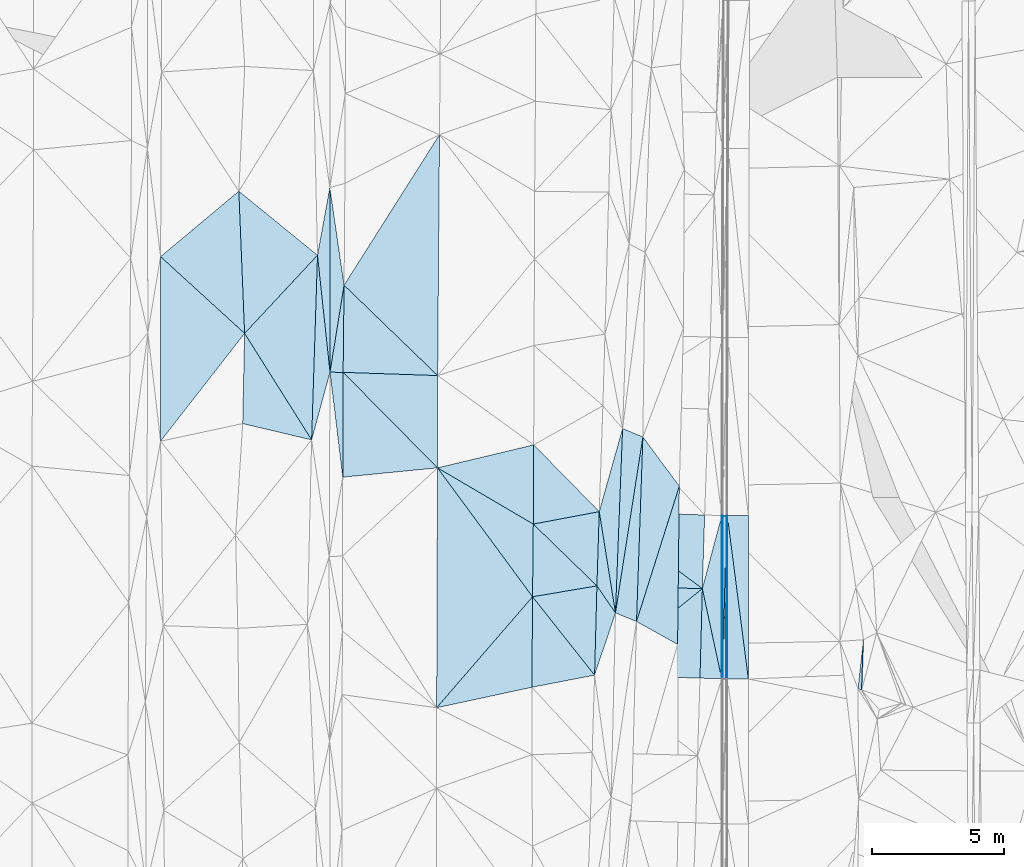
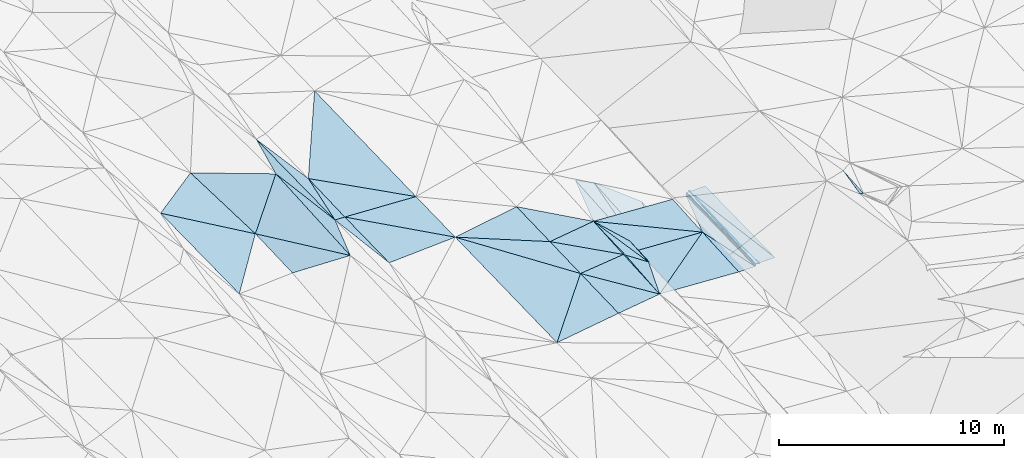
# One storey, part 112 of 275: 45 plates.
"""IFC2X3 building model written with IfcOpenShell, lengths in millimetres."""

from ifc_helpers import new_model, si_unit, frame, origin_with_axes, place, context, subcontext, project, spatial, polyline, outline, extrude, material, type_object, element, save


model = new_model("IFC2X3")

# Units and contexts
model_context = context("Model", 3, precision=1e-05, world=origin_with_axes())
body_context = subcontext(model_context, "Body", "Model", "MODEL_VIEW")
ifc_project = project(units=[si_unit("LENGTHUNIT", "METRE", prefix="MILLI"), si_unit("AREAUNIT", "SQUARE_METRE"), si_unit("VOLUMEUNIT", "CUBIC_METRE"), si_unit("MASSUNIT", "GRAM", prefix="KILO"), si_unit("TIMEUNIT", "SECOND"), si_unit("PLANEANGLEUNIT", "RADIAN"), si_unit("SOLIDANGLEUNIT", "STERADIAN"), si_unit("THERMODYNAMICTEMPERATUREUNIT", "DEGREE_CELSIUS"), si_unit("LUMINOUSINTENSITYUNIT", "LUMEN")], contexts=[model_context])

# Site, building, storey
site_placement = place(None, origin_with_axes())
site = spatial("IfcSite", under=ifc_project, at=site_placement, CompositionType="ELEMENT")
building_placement = place(site_placement, origin_with_axes())
building = spatial("IfcBuilding", under=site, at=building_placement, Name="Undefined", CompositionType="ELEMENT")
storey_placement = place(building_placement, origin_with_axes())
storey = spatial("IfcBuildingStorey", under=building, at=storey_placement, Name="Undefined", CompositionType="ELEMENT", Elevation=0.0)

# Plates
ifc_material = material()
plate_type_1 = type_object("IfcPlateType", PredefinedType="NOTDEFINED")
plate_1_placement = place(storey_placement, frame((-58357.7512393852, 86557.988808777, 42754.5863588415), z_axis=(-0.0308793849775145, 0.0219231411302105, -0.999282662446615), x_axis=(-0.999160849656658, 0.026237675977197, 0.0314512459642161)))
element("IfcPlate", 1, at=plate_1_placement, inside=storey, type_object=plate_type_1, material=ifc_material, Name="00_PR", context=body_context, shape_type="SweptSolid", body=[
    extrude(outline(polyline([(0.0, 0.0), (4002.03540039063, -9.15315467864275e-09), (3989.07470703125, 2818.38940429688), (0.0, 0.0)])), frame((-8.85201319254618e-08, 2.18876761149539e-07, -0.5000001331573), z_axis=(0.0, 0.0, 1.0), x_axis=(1.0, 0.0, 0.0)), (0.0, 0.0, 1.0), 1.0),
])
plate_type_2 = type_object("IfcPlateType", PredefinedType="NOTDEFINED")
plate_2_placement = place(storey_placement, frame((-58357.7512418092, 86557.9887254661, 42754.5863570039), z_axis=(-0.0308838395730228, 0.0217576562930068, -0.999286141626043), x_axis=(-0.779900034065422, -0.625816394072225, 0.010477488973561)))
element("IfcPlate", 2, at=plate_2_placement, inside=storey, type_object=plate_type_2, material=ifc_material, Name="00_PR", context=body_context, shape_type="SweptSolid", body=[
    extrude(outline(polyline([(0.0, 0.0), (5241.14111328125, -2.76777427643538e-08), (3054.173828125, 2586.17651367188), (0.0, 0.0)])), frame((-8.85201319254618e-08, 2.18876761149539e-07, -0.5000001331573), z_axis=(0.0, 0.0, 1.0), x_axis=(1.0, 0.0, 0.0)), (0.0, 0.0, 1.0), 1.0),
])
plate_type_3 = type_object("IfcPlateType", PredefinedType="NOTDEFINED")
plate_3_placement = place(storey_placement, frame((-62445.3176702308, 83277.9971017935, 42809.5003752828), z_axis=(-0.0315103821302001, 0.0225390787356404, -0.999249261069408), x_axis=(0.779900034069693, 0.625816394066865, -0.0104774889758335)))
element("IfcPlate", 3, at=plate_3_placement, inside=storey, type_object=plate_type_3, material=ifc_material, Name="00_PR", context=body_context, shape_type="SweptSolid", body=[
    extrude(outline(polyline([(0.0, 0.0), (5241.14111328125, -2.76777427643538e-08), (3048.486328125, 2592.94506835938), (0.0, 0.0)])), frame((-8.85201319254618e-08, 2.18876761149539e-07, -0.5000001331573), z_axis=(0.0, 0.0, 1.0), x_axis=(1.0, 0.0, 0.0)), (0.0, 0.0, 1.0), 1.0),
])
plate_type_4 = type_object("IfcPlateType", PredefinedType="NOTDEFINED")
plate_4_placement = place(storey_placement, frame((-57589.2338713541, 89327.9691237941, 42956.0087308923), z_axis=(0.970130310864131, 0.00470254512083991, -0.242538792798289), x_axis=(-0.000396513969434212, -0.999780014432471, -0.0209705869750982)))
element("IfcPlate", 4, at=plate_4_placement, inside=storey, type_object=plate_type_4, material=ifc_material, Name="00_PR", context=body_context, shape_type="SweptSolid", body=[
    extrude(outline(polyline([(0.0, 0.0), (6198.68212890625, -2.8441718313843e-08), (6192.9365234375, 123.657730102539), (0.0, 0.0)])), frame((-8.85201319254618e-08, 2.18876761149539e-07, -0.5000001331573), z_axis=(0.0, 0.0, 1.0), x_axis=(1.0, 0.0, 0.0)), (0.0, 0.0, 1.0), 1.0),
])
plate_5_placement = place(storey_placement, frame((-57619.2331588196, 89327.8072825596, 42836.0087344214), z_axis=(0.970131640172993, 0.00470232403322632, -0.242533479923791), x_axis=(0.242529984962054, 0.00130838903510753, 0.970143027863644)))
element("IfcPlate", 5, at=plate_5_placement, inside=storey, type_object=plate_type_4, material=ifc_material, Name="00_PR", context=body_context, shape_type="SweptSolid", body=[
    extrude(outline(polyline([(0.0, 0.0), (123.693099975586, 3.20142135024071e-10), (-134.623916625977, 6188.7822265625), (0.0, 0.0)])), frame((-8.85201319254618e-08, 2.18876761149539e-07, -0.5000001331573), z_axis=(0.0, 0.0, 1.0), x_axis=(1.0, 0.0, 0.0)), (0.0, 0.0, 1.0), 1.0),
])
plate_type_5 = type_object("IfcPlateType", PredefinedType="NOTDEFINED")
plate_6_placement = place(storey_placement, frame((-57439.7190315421, 89327.6508778417, 42955.630111221), z_axis=(4.56291508050687e-05, 0.0209705697998872, -0.999780092380444), x_axis=(-0.024589046977034, -0.999477780056943, -0.0209653509678776)))
element("IfcPlate", 6, at=plate_6_placement, inside=storey, type_object=plate_type_5, material=ifc_material, Name="00_PR", context=body_context, shape_type="SweptSolid", body=[
    extrude(outline(polyline([(0.0, 0.0), (6200.22998046875, 3.74202500097454e-08), (3.36214709281921, 149.962554931641), (0.0, 0.0)])), frame((-8.85201319254618e-08, 2.18876761149539e-07, -0.5000001331573), z_axis=(0.0, 0.0, 1.0), x_axis=(1.0, 0.0, 0.0)), (0.0, 0.0, 1.0), 1.0),
])
plate_7_placement = place(storey_placement, frame((-57592.176767828, 83130.6588104315, 42825.6401126309), z_axis=(6.89482505226201e-05, 0.0209699963333706, -0.999780103072629), x_axis=(0.0245890469681627, 0.999477780057093, 0.0209653509711129)))
element("IfcPlate", 7, at=plate_7_placement, inside=storey, type_object=plate_type_5, material=ifc_material, Name="00_PR", context=body_context, shape_type="SweptSolid", body=[
    extrude(outline(polyline([(0.0, 0.0), (6200.22998046875, 3.74202500097454e-08), (3.19554805755615, 149.972625732422), (0.0, 0.0)])), frame((-8.85201319254618e-08, 2.18876761149539e-07, -0.5000001331573), z_axis=(0.0, 0.0, 1.0), x_axis=(1.0, 0.0, 0.0)), (0.0, 0.0, 1.0), 1.0),
])
plate_type_6 = type_object("IfcPlateType", PredefinedType="NOTDEFINED")
plate_8_placement = place(storey_placement, frame((-57409.708409054, 89327.6241608974, 42956.2302102238), z_axis=(0.0200098356267842, 0.0209580149451509, -0.999580095884141), x_axis=(-0.000395597977113483, -0.999780024464541, -0.0209701259872997)))
element("IfcPlate", 8, at=plate_8_placement, inside=storey, type_object=plate_type_6, material=ifc_material, Name="00_PR", context=body_context, shape_type="SweptSolid", body=[
    extrude(outline(polyline([(0.0, 0.0), (6198.818359375, -2.36468622460961e-08), (-0.00225731660611928, 30.0066528320313), (0.0, 0.0)])), frame((-8.85201319254618e-08, 2.18876761149539e-07, -0.5000001331573), z_axis=(0.0, 0.0, 1.0), x_axis=(1.0, 0.0, 0.0)), (0.0, 0.0, 1.0), 1.0),
])
plate_9_placement = place(storey_placement, frame((-57442.1609558879, 83130.1655951319, 42825.6402119739), z_axis=(0.0199890650627052, 0.0209580318738667, -0.999580511103479), x_axis=(0.000395597976694452, 0.99978002446452, 0.0209701259882881)))
element("IfcPlate", 9, at=plate_9_placement, inside=storey, type_object=plate_type_6, material=ifc_material, Name="00_PR", context=body_context, shape_type="SweptSolid", body=[
    extrude(outline(polyline([(0.0, 0.0), (6198.8486328125, 2.1616870071739e-08), (0.0281949006021023, 30.0062808990479), (0.0, 0.0)])), frame((-8.85201319254618e-08, 2.18876761149539e-07, -0.5000001331573), z_axis=(0.0, 0.0, 1.0), x_axis=(1.0, 0.0, 0.0)), (0.0, 0.0, 1.0), 1.0),
])
plate_type_7 = type_object("IfcPlateType", PredefinedType="NOTDEFINED")
plate_10_placement = place(storey_placement, frame((-62267.6399642739, 89479.394835255, 42939.5003587584), z_axis=(-0.0300674625925646, 0.0230098048793005, -0.999282991235547), x_axis=(0.99902970947299, -0.0314947660320381, -0.0307850499902134)))
element("IfcPlate", 10, at=plate_10_placement, inside=storey, type_object=plate_type_7, material=ifc_material, Name="00_PR", context=body_context, shape_type="SweptSolid", body=[
    extrude(outline(polyline([(0.0, 0.0), (4001.91015625, 1.07684172689915e-09), (4003.796875, 2797.435546875), (0.0, 0.0)])), frame((-8.85201319254618e-08, 2.18876761149539e-07, -0.5000001331573), z_axis=(0.0, 0.0, 1.0), x_axis=(1.0, 0.0, 0.0)), (0.0, 0.0, 1.0), 1.0),
])
plate_type_8 = type_object("IfcPlateType", PredefinedType="NOTDEFINED")
plate_11_placement = place(storey_placement, frame((-57622.1564597895, 83138.9308167229, 42705.8233482873), z_axis=(0.0309019425874492, 0.0209003240402177, -0.999303880908773), x_axis=(-0.999072922252713, 0.0306263970346094, -0.0302542530250422)))
element("IfcPlate", 11, at=plate_11_placement, inside=storey, type_object=plate_type_8, material=ifc_material, Name="00_PR", context=body_context, shape_type="SweptSolid", body=[
    extrude(outline(polyline([(0.0, 0.0), (825.503784179688, -2.91038304567337e-10), (838.120056152344, 3395.72387695313), (0.0, 0.0)])), frame((-8.85201319254618e-08, 2.18876761149539e-07, -0.5000001331573), z_axis=(0.0, 0.0, 1.0), x_axis=(1.0, 0.0, 0.0)), (0.0, 0.0, 1.0), 1.0),
])
plate_type_9 = type_object("IfcPlateType", PredefinedType="NOTDEFINED")
plate_12_placement = place(storey_placement, frame((-58357.7202340507, 86557.988323969, 42754.5863524246), z_axis=(0.0311199505295665, 0.0209471150676176, -0.999296135812293), x_axis=(0.257363410156783, 0.96590131045232, 0.0282618750079025)))
element("IfcPlate", 12, at=plate_12_placement, inside=storey, type_object=plate_type_9, material=ifc_material, Name="00_PR", context=body_context, shape_type="SweptSolid", body=[
    extrude(outline(polyline([(0.0, 0.0), (2867.60888671875, -3.56521923094988e-09), (-3114.54296875, 1591.54260253906), (0.0, 0.0)])), frame((-8.85201319254618e-08, 2.18876761149539e-07, -0.5000001331573), z_axis=(0.0, 0.0, 1.0), x_axis=(1.0, 0.0, 0.0)), (0.0, 0.0, 1.0), 1.0),
])
plate_type_10 = type_object("IfcPlateType", PredefinedType="NOTDEFINED")
plate_13_placement = place(storey_placement, frame((-56609.7092347009, 89326.8921957536, 42972.2302104516), z_axis=(0.0200107994602655, 0.0209608191733525, -0.999580017789743), x_axis=(-0.000395519029052022, -0.999779965678758, -0.0209729299831959)))
element("IfcPlate", 13, at=plate_13_placement, inside=storey, type_object=plate_type_10, material=ifc_material, Name="00_PR", context=body_context, shape_type="SweptSolid", body=[
    extrude(outline(polyline([(0.0, 0.0), (6197.9892578125, -4.14365786127746e-08), (-0.0798222273588181, 800.159484863281), (0.0, 0.0)])), frame((-8.85201319254618e-08, 2.18876761149539e-07, -0.5000001331573), z_axis=(0.0, 0.0, 1.0), x_axis=(1.0, 0.0, 0.0)), (0.0, 0.0, 1.0), 1.0),
])
plate_14_placement = place(storey_placement, frame((-57412.1606596844, 83130.1693441346, 42826.2402103188), z_axis=(0.0199890650627052, 0.0209580318738667, -0.999580511103479), x_axis=(0.000395597976694452, 0.99978002446452, 0.0209701259882881)))
element("IfcPlate", 14, at=plate_14_placement, inside=storey, type_object=plate_type_10, material=ifc_material, Name="00_PR", context=body_context, shape_type="SweptSolid", body=[
    extrude(outline(polyline([(0.0, 0.0), (6198.818359375, -2.36468622460961e-08), (0.749144852161407, 800.159606933594), (0.0, 0.0)])), frame((-8.85201319254618e-08, 2.18876761149539e-07, -0.5000001331573), z_axis=(0.0, 0.0, 1.0), x_axis=(1.0, 0.0, 0.0)), (0.0, 0.0, 1.0), 1.0),
])
plate_type_11 = type_object("IfcPlateType", PredefinedType="NOTDEFINED")
plate_15_placement = place(storey_placement, frame((-68403.1708053464, 91140.363477032, 43219.5002137461), z_axis=(-0.0239883814838285, 0.0176858322564029, -0.999555785782457), x_axis=(-0.994956464147251, -0.0978322305697529, 0.0221469888099441)))
element("IfcPlate", 15, at=plate_15_placement, inside=storey, type_object=plate_type_11, material=ifc_material, Name="00", context=body_context, shape_type="SweptSolid", body=[
    extrude(outline(polyline([(0.0, 0.0), (3612.22924804688, -1.29948602989316e-08), (3211.06420898438, 3955.40991210938), (0.0, 0.0)])), frame((-8.85201319254618e-08, 2.18876761149539e-07, -0.5000001331573), z_axis=(0.0, 0.0, 1.0), x_axis=(1.0, 0.0, 0.0)), (0.0, 0.0, 1.0), 1.0),
])
plate_type_12 = type_object("IfcPlateType", PredefinedType="NOTDEFINED")
plate_16_placement = place(storey_placement, frame((-72480.7856506035, 94769.507921843, 43379.5001327477), z_axis=(-0.0128943731053656, 0.0202643604748722, -0.999711503803354), x_axis=(-0.000922481699084824, 0.999793956063044, 0.0202779300551677)))
element("IfcPlate", 16, at=plate_16_placement, inside=storey, type_object=plate_type_12, material=ifc_material, Name="00", context=body_context, shape_type="SweptSolid", body=[
    extrude(outline(polyline([(0.0, 0.0), (7002.68701171875, 1.41590135172009e-08), (3299.48803710938, 536.532043457031), (0.0, 0.0)])), frame((-8.85201319254618e-08, 2.18876761149539e-07, -0.5000001331573), z_axis=(0.0, 0.0, 1.0), x_axis=(1.0, 0.0, 0.0)), (0.0, 0.0, 1.0), 1.0),
])
plate_type_13 = type_object("IfcPlateType", PredefinedType="NOTDEFINED")
plate_17_placement = place(storey_placement, frame((-59230.2451748408, 90446.136404258, 42373.5111837381), z_axis=(-0.208792209515338, 0.026083710498339, -0.977612118016313), x_axis=(-0.0110111094596604, -0.999643586667625, -0.0243198499739393)))
element("IfcPlate", 17, at=plate_17_placement, inside=storey, type_object=plate_type_13, material=ifc_material, Name="00", context=body_context, shape_type="SweptSolid", body=[
    extrude(outline(polyline([(0.0, 0.0), (6003.32666015625, 1.08557287603617e-08), (5145.32275390625, 1603.47106933594), (0.0, 0.0)])), frame((-8.85201319254618e-08, 2.18876761149539e-07, -0.5000001331573), z_axis=(0.0, 0.0, 1.0), x_axis=(1.0, 0.0, 0.0)), (0.0, 0.0, 1.0), 1.0),
])
plate_type_14 = type_object("IfcPlateType", PredefinedType="NOTDEFINED")
plate_18_placement = place(storey_placement, frame((-62445.3187485317, 83277.9961701216, 42809.5003755525), z_axis=(-0.0334201914633874, 0.020609182497898, -0.999228878885773), x_axis=(-0.981344011971912, -0.190075306667745, 0.0289016947951841)))
element("IfcPlate", 18, at=plate_18_placement, inside=storey, type_object=plate_type_14, material=ifc_material, Name="00", context=body_context, shape_type="SweptSolid", body=[
    extrude(outline(polyline([(0.0, 0.0), (2422.00341796875, 2.53203324973583e-09), (1747.97448730469, 3366.83618164063), (0.0, 0.0)])), frame((-8.85201319254618e-08, 2.18876761149539e-07, -0.5000001331573), z_axis=(0.0, 0.0, 1.0), x_axis=(1.0, 0.0, 0.0)), (0.0, 0.0, 1.0), 1.0),
])
plate_type_15 = type_object("IfcPlateType", PredefinedType="NOTDEFINED")
plate_19_placement = place(storey_placement, frame((-71997.1795523155, 90786.9710265653, 43299.500166944), z_axis=(-0.0198276389083265, 0.0176728968193353, -0.999647204494333), x_axis=(-0.120523082647133, 0.99251029841049, 0.0199372540324)))
element("IfcPlate", 19, at=plate_19_placement, inside=storey, type_object=plate_type_15, material=ifc_material, Name="00", context=body_context, shape_type="SweptSolid", body=[
    extrude(outline(polyline([(0.0, 0.0), (4012.58862304688, -4.17639967054129e-09), (3945.00927734375, 493.052764892578), (0.0, 0.0)])), frame((-8.85201319254618e-08, 2.18876761149539e-07, -0.5000001331573), z_axis=(0.0, 0.0, 1.0), x_axis=(1.0, 0.0, 0.0)), (0.0, 0.0, 1.0), 1.0),
])
plate_type_16 = type_object("IfcPlateType", PredefinedType="NOTDEFINED")
plate_20_placement = place(storey_placement, frame((-64798.1446093903, 86250.4770295495, 42949.5006944645), z_axis=(-0.0495454761859882, 0.0186115156812972, -0.998598446460612), x_axis=(-0.592823398462132, 0.804107637728591, 0.0443996079076491)))
element("IfcPlate", 20, at=plate_20_placement, inside=storey, type_object=plate_type_16, material=ifc_material, Name="00", context=body_context, shape_type="SweptSolid", body=[
    extrude(outline(polyline([(0.0, 0.0), (6081.134765625, -2.80861058854498e-08), (2202.38500976563, 1658.82495117188), (0.0, 0.0)])), frame((-8.85201319254618e-08, 2.18876761149539e-07, -0.5000001331573), z_axis=(0.0, 0.0, 1.0), x_axis=(1.0, 0.0, 0.0)), (0.0, 0.0, 1.0), 1.0),
])
plate_type_17 = type_object("IfcPlateType", PredefinedType="NOTDEFINED")
plate_21_placement = place(storey_placement, frame((-52247.076673411, 84620.1653144786, 45129.5055502483), z_axis=(0.147219517990888, 0.0209946419064816, -0.988881003222202), x_axis=(-0.0333183933728195, -0.999102054661069, -0.0261719130955952)))
element("IfcPlate", 21, at=plate_21_placement, inside=storey, type_object=plate_type_17, material=ifc_material, Name="00", context=body_context, shape_type="SweptSolid", body=[
    extrude(outline(polyline([(0.0, 0.0), (1910.44494628906, 4.86761564388871e-09), (1868.72692871094, 144.081939697266), (0.0, 0.0)])), frame((-8.85201319254618e-08, 2.18876761149539e-07, -0.5000001331573), z_axis=(0.0, 0.0, 1.0), x_axis=(1.0, 0.0, 0.0)), (0.0, 0.0, 1.0), 1.0),
])
plate_type_18 = type_object("IfcPlateType", PredefinedType="NOTDEFINED")
plate_22_placement = place(storey_placement, frame((-62356.4218409509, 86662.9925557822, 42879.5001797734), z_axis=(-0.0175557684301573, 0.0211326954335848, -0.999622530847789), x_axis=(0.565798587697166, -0.824089476832664, -0.0273585879306403)))
element("IfcPlate", 22, at=plate_22_placement, inside=storey, type_object=plate_type_18, material=ifc_material, Name="00", context=body_context, shape_type="SweptSolid", body=[
    extrude(outline(polyline([(0.0, 0.0), (1242.75415039063, -3.17913873004727e-09), (2741.16162109375, 1989.22937011719), (0.0, 0.0)])), frame((-8.85201319254618e-08, 2.18876761149539e-07, -0.5000001331573), z_axis=(0.0, 0.0, 1.0), x_axis=(1.0, 0.0, 0.0)), (0.0, 0.0, 1.0), 1.0),
])
plate_type_19 = type_object("IfcPlateType", PredefinedType="NOTDEFINED")
plate_23_placement = place(storey_placement, frame((-71947.3456008616, 98068.9517702174, 43439.5002009378), z_axis=(-0.0197706053573297, 0.0213736248542341, -0.999576055797854), x_axis=(-0.0108643193109169, -0.999717033330351, -0.0211617540641613)))
element("IfcPlate", 23, at=plate_23_placement, inside=storey, type_object=plate_type_19, material=ifc_material, Name="00", context=body_context, shape_type="SweptSolid", body=[
    extrude(outline(polyline([(0.0, 0.0), (3307.85424804688, -3.79804987460375e-09), (3305.57495117188, 497.657318115234), (0.0, 0.0)])), frame((-8.85201319254618e-08, 2.18876761149539e-07, -0.5000001331573), z_axis=(0.0, 0.0, 1.0), x_axis=(1.0, 0.0, 0.0)), (0.0, 0.0, 1.0), 1.0),
])
plate_type_20 = type_object("IfcPlateType", PredefinedType="NOTDEFINED")
plate_24_placement = place(storey_placement, frame((-61653.3872223845, 85638.8536369362, 42845.5154480836), z_axis=(-0.245460033850752, 0.0246222920576859, -0.969093965782377), x_axis=(0.038746194473814, 0.999127751174424, 0.0155714240497232)))
element("IfcPlate", 24, at=plate_24_placement, inside=storey, type_object=plate_type_20, material=ifc_material, Name="00", context=body_context, shape_type="SweptSolid", body=[
    extrude(outline(polyline([(0.0, 0.0), (7000.001953125, -4.77593857795e-08), (6704.35888671875, 805.834533691406), (0.0, 0.0)])), frame((-8.85201319254618e-08, 2.18876761149539e-07, -0.5000001331573), z_axis=(0.0, 0.0, 1.0), x_axis=(1.0, 0.0, 0.0)), (0.0, 0.0, 1.0), 1.0),
])
plate_type_21 = type_object("IfcPlateType", PredefinedType="NOTDEFINED")
plate_25_placement = place(storey_placement, frame((-62267.6333411099, 89479.3942700607, 42939.5001785627), z_axis=(-0.016558038696658, 0.0218177874597188, -0.999624837378945), x_axis=(0.157912761647233, -0.987157427858583, -0.0241613810153823)))
element("IfcPlate", 25, at=plate_25_placement, inside=storey, type_object=plate_type_21, material=ifc_material, Name="00", context=body_context, shape_type="SweptSolid", body=[
    extrude(outline(polyline([(0.0, 0.0), (3890.50610351563, -2.30647856369615e-08), (2767.66040039063, 532.59326171875), (0.0, 0.0)])), frame((-8.85201319254618e-08, 2.18876761149539e-07, -0.5000001331573), z_axis=(0.0, 0.0, 1.0), x_axis=(1.0, 0.0, 0.0)), (0.0, 0.0, 1.0), 1.0),
])
plate_type_22 = type_object("IfcPlateType", PredefinedType="NOTDEFINED")
plate_26_placement = place(storey_placement, frame((-61382.0634033553, 92632.7460947643, 42954.5005669035), z_axis=(-0.0446823056539354, 0.017299898504161, -0.998851442944943), x_axis=(-0.0387461944115704, -0.999127751176749, -0.0155714240553799)))
element("IfcPlate", 26, at=plate_26_placement, inside=storey, type_object=plate_type_22, material=ifc_material, Name="00", context=body_context, shape_type="SweptSolid", body=[
    extrude(outline(polyline([(0.0, 0.0), (7000.001953125, -4.77593857795e-08), (3185.15014648438, 763.507995605469), (0.0, 0.0)])), frame((-8.85201319254618e-08, 2.18876761149539e-07, -0.5000001331573), z_axis=(0.0, 0.0, 1.0), x_axis=(1.0, 0.0, 0.0)), (0.0, 0.0, 1.0), 1.0),
])
plate_type_23 = type_object("IfcPlateType", PredefinedType="NOTDEFINED")
plate_27_placement = place(storey_placement, frame((-73178.7191740225, 92200.9229686816, 43254.5061158536), z_axis=(0.156028016657636, 0.00476713516788253, -0.987741126226997), x_axis=(-0.961984483436774, 0.22765526159537, -0.150860649258934)))
element("IfcPlate", 27, at=plate_27_placement, inside=storey, type_object=plate_type_23, material=ifc_material, Name="00", context=body_context, shape_type="SweptSolid", body=[
    extrude(outline(polyline([(0.0, 0.0), (2717.73999023438, -4.20550350099802e-09), (3422.50561523438, 3349.11767578125), (0.0, 0.0)])), frame((-8.85201319254618e-08, 2.18876761149539e-07, -0.5000001331573), z_axis=(0.0, 0.0, 1.0), x_axis=(1.0, 0.0, 0.0)), (0.0, 0.0, 1.0), 1.0),
])
plate_type_24 = type_object("IfcPlateType", PredefinedType="NOTDEFINED")
plate_28_placement = place(storey_placement, frame((-73178.7282603699, 92200.9259472996, 43254.5047933781), z_axis=(0.137852035115286, 0.0107359549826008, -0.990394646434029), x_axis=(0.0318674134473679, 0.999375469291305, 0.0152689010396566)))
element("IfcPlate", 28, at=plate_28_placement, inside=storey, type_object=plate_type_24, material=ifc_material, Name="00", context=body_context, shape_type="SweptSolid", body=[
    extrude(outline(polyline([(0.0, 0.0), (7007.7080078125, -4.49654180556536e-09), (2591.12573242188, 621.699768066406), (0.0, 0.0)])), frame((-8.85201319254618e-08, 2.18876761149539e-07, -0.5000001331573), z_axis=(0.0, 0.0, 1.0), x_axis=(1.0, 0.0, 0.0)), (0.0, 0.0, 1.0), 1.0),
])
plate_type_25 = type_object("IfcPlateType", PredefinedType="NOTDEFINED")
plate_29_placement = place(storey_placement, frame((-71983.2826675009, 94762.0342389859, 43369.5002092274), z_axis=(-0.0187472293569717, 0.0228671358770325, -0.999562722138145), x_axis=(0.999242906122798, -0.0336589604161772, -0.0195112518041985)))
element("IfcPlate", 29, at=plate_29_placement, inside=storey, type_object=plate_type_25, material=ifc_material, Name="00", context=body_context, shape_type="SweptSolid", body=[
    extrude(outline(polyline([(0.0, 0.0), (3587.67333984375, -2.45345290750265e-08), (3702.23217773438, 3499.95385742188), (0.0, 0.0)])), frame((-8.85201319254618e-08, 2.18876761149539e-07, -0.5000001331573), z_axis=(0.0, 0.0, 1.0), x_axis=(1.0, 0.0, 0.0)), (0.0, 0.0, 1.0), 1.0),
])
plate_type_26 = type_object("IfcPlateType", PredefinedType="NOTDEFINED")
plate_30_placement = place(storey_placement, frame((-78907.7198958552, 99152.0802098772, 43339.504368235), z_axis=(-0.131131880590606, 0.0154505270378207, -0.991244526394484), x_axis=(0.764073569565225, 0.638661012347216, -0.0911245938234272)))
element("IfcPlate", 30, at=plate_30_placement, inside=storey, type_object=plate_type_26, material=ifc_material, Name="00", context=body_context, shape_type="SweptSolid", body=[
    extrude(outline(polyline([(0.0, 0.0), (3884.791015625, -1.27765815705061e-08), (618.716186523438, 4297.24609375), (0.0, 0.0)])), frame((-8.85201319254618e-08, 2.18876761149539e-07, -0.5000001331573), z_axis=(0.0, 0.0, 1.0), x_axis=(1.0, 0.0, 0.0)), (0.0, 0.0, 1.0), 1.0),
])
plate_type_27 = type_object("IfcPlateType", PredefinedType="NOTDEFINED")
plate_31_placement = place(storey_placement, frame((-75720.4323816063, 96241.2220995835, 42872.5055513826), z_axis=(0.146311951017579, 0.0266636500910163, -0.988879094102638), x_axis=(-0.0405522115743926, 0.998958070437139, 0.0209354160439526)))
element("IfcPlate", 31, at=plate_31_placement, inside=storey, type_object=plate_type_27, material=ifc_material, Name="00", context=body_context, shape_type="SweptSolid", body=[
    extrude(outline(polyline([(0.0, 0.0), (5397.55224609375, 4.9622030928731e-09), (2858.0654296875, 2914.71728515625), (0.0, 0.0)])), frame((-8.85201319254618e-08, 2.18876761149539e-07, -0.5000001331573), z_axis=(0.0, 0.0, 1.0), x_axis=(1.0, 0.0, 0.0)), (0.0, 0.0, 1.0), 1.0),
])
plate_type_28 = type_object("IfcPlateType", PredefinedType="NOTDEFINED")
plate_32_placement = place(storey_placement, frame((-62267.6392541747, 89479.395088414, 42939.5003300941), z_axis=(-0.0283832358899944, 0.023452653110788, -0.999321952617112), x_axis=(-0.982383089695069, -0.18538824061362, 0.023551333791467)))
element("IfcPlate", 32, at=plate_32_placement, inside=storey, type_object=plate_type_28, material=ifc_material, Name="00", context=body_context, shape_type="SweptSolid", body=[
    extrude(outline(polyline([(0.0, 0.0), (2547.62646484375, 1.86264514923096e-09), (1975.72143554688, 2949.29223632813), (0.0, 0.0)])), frame((-8.85201319254618e-08, 2.18876761149539e-07, -0.5000001331573), z_axis=(0.0, 0.0, 1.0), x_axis=(1.0, 0.0, 0.0)), (0.0, 0.0, 1.0), 1.0),
])
plate_type_29 = type_object("IfcPlateType", PredefinedType="NOTDEFINED")
plate_33_placement = place(storey_placement, frame((-64770.3841745187, 89007.0944849422, 42999.5003106724), z_axis=(-0.0281434272185843, 0.0221773326206091, -0.999357850533145), x_axis=(0.982383089696406, 0.185388240607206, -0.0235513337861778)))
element("IfcPlate", 33, at=plate_33_placement, inside=storey, type_object=plate_type_29, material=ifc_material, Name="00", context=body_context, shape_type="SweptSolid", body=[
    extrude(outline(polyline([(0.0, 0.0), (2547.62646484375, 1.86264514923096e-09), (1939.68786621094, 2752.09204101563), (0.0, 0.0)])), frame((-8.85201319254618e-08, 2.18876761149539e-07, -0.5000001331573), z_axis=(0.0, 0.0, 1.0), x_axis=(1.0, 0.0, 0.0)), (0.0, 0.0, 1.0), 1.0),
])
plate_type_30 = type_object("IfcPlateType", PredefinedType="NOTDEFINED")
plate_34_placement = place(storey_placement, frame((-64770.3934295061, 89007.0951657957, 42999.5006728676), z_axis=(-0.0466532255477857, 0.0235404239407209, -0.998633729145315), x_axis=(-0.861140589569286, 0.505684915564674, 0.0521502748469363)))
element("IfcPlate", 34, at=plate_34_placement, inside=storey, type_object=plate_type_30, material=ifc_material, Name="00", context=body_context, shape_type="SweptSolid", body=[
    extrude(outline(polyline([(0.0, 0.0), (4218.578125, -2.16823536902666e-09), (1507.7119140625, 2598.50048828125), (0.0, 0.0)])), frame((-8.85201319254618e-08, 2.18876761149539e-07, -0.5000001331573), z_axis=(0.0, 0.0, 1.0), x_axis=(1.0, 0.0, 0.0)), (0.0, 0.0, 1.0), 1.0),
])
plate_type_31 = type_object("IfcPlateType", PredefinedType="NOTDEFINED")
plate_35_placement = place(storey_placement, frame((-64798.1414084912, 86250.4780598542, 42949.5005619655), z_axis=(-0.0431405578295789, 0.0206695217421395, -0.998855176259854), x_axis=(-0.00698984833491256, -0.999767739060438, -0.0203865140285257)))
element("IfcPlate", 35, at=plate_35_placement, inside=storey, type_object=plate_type_31, material=ifc_material, Name="00", context=body_context, shape_type="SweptSolid", body=[
    extrude(outline(polyline([(0.0, 0.0), (3433.64233398438, 1.70693965628743e-08), (4233.63818359375, 3611.99487304688), (0.0, 0.0)])), frame((-8.85201319254618e-08, 2.18876761149539e-07, -0.5000001331573), z_axis=(0.0, 0.0, 1.0), x_axis=(1.0, 0.0, 0.0)), (0.0, 0.0, 1.0), 1.0),
])
plate_type_32 = type_object("IfcPlateType", PredefinedType="NOTDEFINED")
plate_36_placement = place(storey_placement, frame((-64798.135978743, 86250.4784800183, 42949.500365872), z_axis=(-0.032281174004667, 0.0215116200440496, -0.999247304728895), x_axis=(0.985633479220463, 0.166517893707915, -0.0282566048003717)))
element("IfcPlate", 36, at=plate_36_placement, inside=storey, type_object=plate_type_32, material=ifc_material, Name="00", context=body_context, shape_type="SweptSolid", body=[
    extrude(outline(polyline([(0.0, 0.0), (2477.296875, -1.02591002359986e-08), (1828.00048828125, 3324.06591796875), (0.0, 0.0)])), frame((-8.85201319254618e-08, 2.18876761149539e-07, -0.5000001331573), z_axis=(0.0, 0.0, 1.0), x_axis=(1.0, 0.0, 0.0)), (0.0, 0.0, 1.0), 1.0),
])
plate_type_33 = type_object("IfcPlateType", PredefinedType="NOTDEFINED")
plate_37_placement = place(storey_placement, frame((-68436.2784956889, 82039.8654531598, 43019.5006132363), z_axis=(-0.0448083832292321, 0.02211232307333, -0.998750846788469), x_axis=(0.00363596133230829, 0.999751988741365, 0.0219713630181443)))
element("IfcPlate", 37, at=plate_37_placement, inside=storey, type_object=plate_type_33, material=ifc_material, Name="00", context=body_context, shape_type="SweptSolid", body=[
    extrude(outline(polyline([(0.0, 0.0), (9102.7578125, 3.34694050252438e-08), (4221.25927734375, 3626.45434570313), (0.0, 0.0)])), frame((-8.85201319254618e-08, 2.18876761149539e-07, -0.5000001331573), z_axis=(0.0, 0.0, 1.0), x_axis=(1.0, 0.0, 0.0)), (0.0, 0.0, 1.0), 1.0),
])
plate_type_34 = type_object("IfcPlateType", PredefinedType="NOTDEFINED")
plate_38_placement = place(storey_placement, frame((-62356.428945652, 86662.9912119983, 42879.5003283666), z_axis=(-0.0317654351912761, 0.0184457123844876, -0.999325128685223), x_axis=(-0.985633479220451, -0.166517893707309, 0.028256604804369)))
element("IfcPlate", 38, at=plate_38_placement, inside=storey, type_object=plate_type_34, material=ifc_material, Name="00", context=body_context, shape_type="SweptSolid", body=[
    extrude(outline(polyline([(0.0, 0.0), (2477.296875, -1.02591002359986e-08), (1992.33288574219, 2714.2236328125), (0.0, 0.0)])), frame((-8.85201319254618e-08, 2.18876761149539e-07, -0.5000001331573), z_axis=(0.0, 0.0, 1.0), x_axis=(1.0, 0.0, 0.0)), (0.0, 0.0, 1.0), 1.0),
])
plate_type_35 = type_object("IfcPlateType", PredefinedType="NOTDEFINED")
plate_39_placement = place(storey_placement, frame((-68398.3255628566, 94641.2761348067, 43299.5001919079), z_axis=(-0.0187985105797265, 0.0213634625423572, -0.999595027232622), x_axis=(-0.999242906126247, 0.0336589603127304, 0.0195112518060255)))
element("IfcPlate", 39, at=plate_39_placement, inside=storey, type_object=plate_type_35, material=ifc_material, Name="00", context=body_context, shape_type="SweptSolid", body=[
    extrude(outline(polyline([(0.0, 0.0), (3587.67333984375, -2.45345290750265e-08), (3664.43627929688, 3306.96337890625), (0.0, 0.0)])), frame((-8.85201319254618e-08, 2.18876761149539e-07, -0.5000001331573), z_axis=(0.0, 0.0, 1.0), x_axis=(1.0, 0.0, 0.0)), (0.0, 0.0, 1.0), 1.0),
])
plate_type_36 = type_object("IfcPlateType", PredefinedType="NOTDEFINED")
plate_40_placement = place(storey_placement, frame((-73178.7152362189, 92200.9254999049, 43254.5067775548), z_axis=(0.163901842322637, 0.00984468488429087, -0.986427528135126), x_axis=(-0.530789617557685, 0.843740794874732, -0.0797737610817062)))
element("IfcPlate", 40, at=plate_40_placement, inside=storey, type_object=plate_type_36, material=ifc_material, Name="00", context=body_context, shape_type="SweptSolid", body=[
    extrude(outline(polyline([(0.0, 0.0), (4788.5419921875, -3.90618879464455e-08), (5781.92578125, 3959.45727539063), (0.0, 0.0)])), frame((-8.85201319254618e-08, 2.18876761149539e-07, -0.5000001331573), z_axis=(0.0, 0.0, 1.0), x_axis=(1.0, 0.0, 0.0)), (0.0, 0.0, 1.0), 1.0),
])
plate_type_37 = type_object("IfcPlateType", PredefinedType="NOTDEFINED")
plate_41_placement = place(storey_placement, frame((-68327.5860462064, 103780.284391351, 43469.5001935722), z_axis=(-0.0213139379519718, 0.0187590598560527, -0.999596825586344), x_axis=(-0.00773895842961989, -0.999797094518732, -0.0185978040189333)))
element("IfcPlate", 41, at=plate_41_placement, inside=storey, type_object=plate_type_37, material=ifc_material, Name="00", context=body_context, shape_type="SweptSolid", body=[
    extrude(outline(polyline([(0.0, 0.0), (9140.8642578125, 5.84113877266645e-08), (5738.74609375, 3576.26782226563), (0.0, 0.0)])), frame((-8.85201319254618e-08, 2.18876761149539e-07, -0.5000001331573), z_axis=(0.0, 0.0, 1.0), x_axis=(1.0, 0.0, 0.0)), (0.0, 0.0, 1.0), 1.0),
])
plate_type_38 = type_object("IfcPlateType", PredefinedType="NOTDEFINED")
plate_42_placement = place(storey_placement, frame((-72480.6674284709, 94769.5077728811, 43379.5127446541), z_axis=(0.22352510457431, 0.0199710252904382, -0.974493553479905), x_axis=(-0.106432115509973, 0.99431178078777, -0.00403576197574066)))
element("IfcPlate", 42, at=plate_42_placement, inside=storey, type_object=plate_type_38, material=ifc_material, Name="00", context=body_context, shape_type="SweptSolid", body=[
    extrude(outline(polyline([(0.0, 0.0), (4460.12451171875, 1.93831510841846e-08), (6961.5341796875, 758.069763183594), (0.0, 0.0)])), frame((-8.85201319254618e-08, 2.18876761149539e-07, -0.5000001331573), z_axis=(0.0, 0.0, 1.0), x_axis=(1.0, 0.0, 0.0)), (0.0, 0.0, 1.0), 1.0),
])
plate_type_39 = type_object("IfcPlateType", PredefinedType="NOTDEFINED")
plate_43_placement = place(storey_placement, frame((-59230.2529209628, 90446.1389166894, 42373.5129829828), z_axis=(-0.224288769075882, 0.0311340467916204, -0.974025266200422), x_axis=(-0.301460570596149, -0.952682116474083, 0.0389654889139904)))
element("IfcPlate", 43, at=plate_43_placement, inside=storey, type_object=plate_type_39, material=ifc_material, Name="00", context=body_context, shape_type="SweptSolid", body=[
    extrude(outline(polyline([(0.0, 0.0), (5389.38427734375, -3.97703843191266e-08), (-1344.26000976563, 1929.42114257813), (0.0, 0.0)])), frame((-8.85201319254618e-08, 2.18876761149539e-07, -0.5000001331573), z_axis=(0.0, 0.0, 1.0), x_axis=(1.0, 0.0, 0.0)), (0.0, 0.0, 1.0), 1.0),
])
plate_type_40 = type_object("IfcPlateType", PredefinedType="NOTDEFINED")
plate_44_placement = place(storey_placement, frame((-75720.5694470913, 96241.2183317148, 42872.504183898), z_axis=(-0.127829012567561, 0.0191258084202508, -0.991611792486492), x_axis=(-0.613432854750006, -0.787157864524383, 0.0638954539123932)))
element("IfcPlate", 44, at=plate_44_placement, inside=storey, type_object=plate_type_40, material=ifc_material, Name="00", context=body_context, shape_type="SweptSolid", body=[
    extrude(outline(polyline([(0.0, 0.0), (5195.98779296875, 2.99769453704357e-08), (-306.368316650391, 4330.73583984375), (0.0, 0.0)])), frame((-8.85201319254618e-08, 2.18876761149539e-07, -0.5000001331573), z_axis=(0.0, 0.0, 1.0), x_axis=(1.0, 0.0, 0.0)), (0.0, 0.0, 1.0), 1.0),
])
plate_type_41 = type_object("IfcPlateType", PredefinedType="NOTDEFINED")
plate_45_placement = place(storey_placement, frame((-60854.9773406523, 85311.769769864, 42583.523198194), z_axis=(-0.299294120841135, 0.0332357301232147, -0.953581887135609), x_axis=(-0.885441795455806, 0.362730711650638, 0.290549922879735)))
element("IfcPlate", 45, at=plate_45_placement, inside=storey, type_object=plate_type_41, material=ifc_material, Name="00", context=body_context, shape_type="SweptSolid", body=[
    extrude(outline(polyline([(0.0, 0.0), (901.738342285156, -5.45696821063757e-10), (2373.17626953125, 6590.3466796875), (0.0, 0.0)])), frame((-8.85201319254618e-08, 2.18876761149539e-07, -0.5000001331573), z_axis=(0.0, 0.0, 1.0), x_axis=(1.0, 0.0, 0.0)), (0.0, 0.0, 1.0), 1.0),
])

save(model, "model.ifc")
